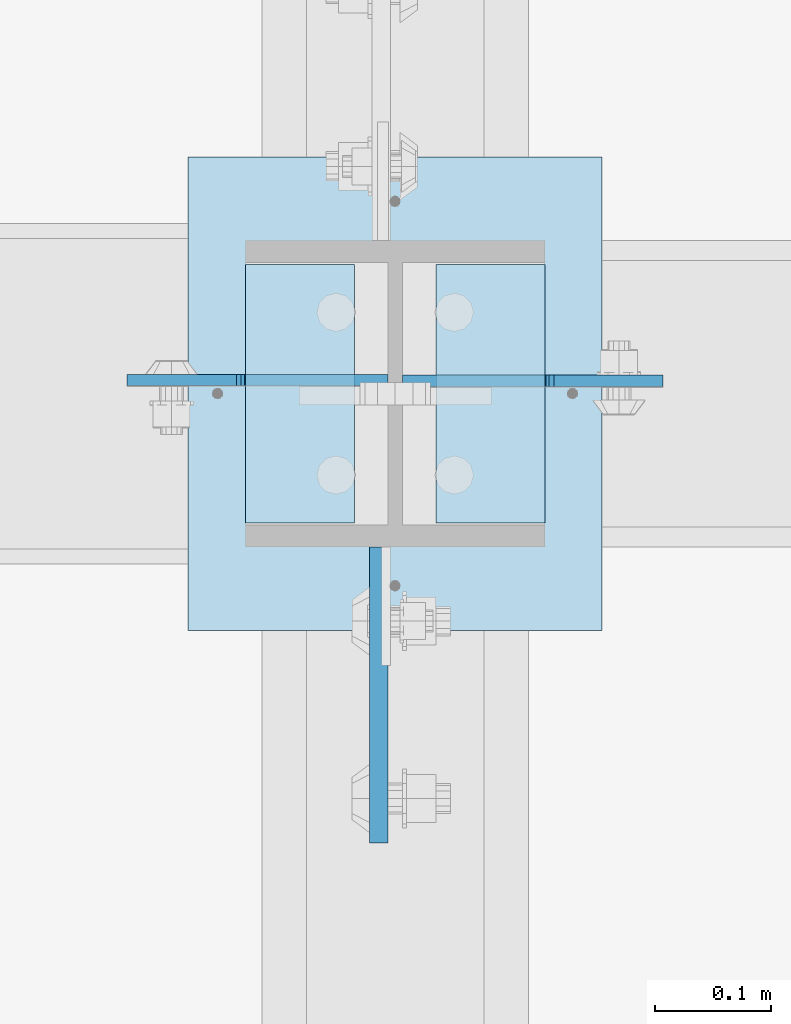
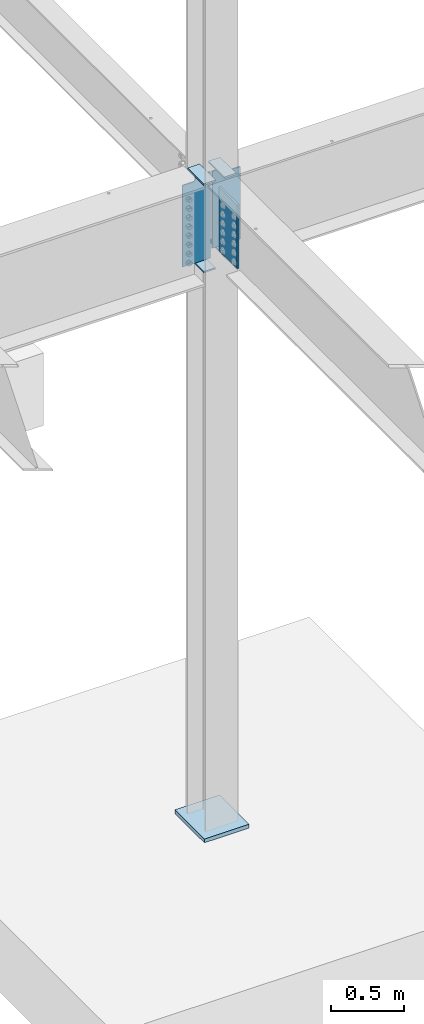
# One storey, part 1564 of 1763: 8 plates, 1 element without a shape of its own.
"""IFC2X3 building model written with IfcOpenShell, lengths in millimetres."""

import ifcopenshell
import ifcopenshell.guid

model = None  # the IFC model being written
_history = None  # IfcOwnerHistory: only IFC2X3 demands one
_inside = {}  # id of a spatial element -> (the spatial element, [elements in it])
_under = {}  # id of a project, library or spatial element -> (it, [spatial elements below it])
_declared = {}  # id of a project -> (the project, [libraries it declares])
_typed = {}  # id of a type object -> (the type object, [elements of that type])
_made_of = {}  # id of a material, layer set ... -> (it, [elements and type objects made of it])


def new_model(schema):
    """Start an empty IFC model of exactly this schema.

    Asked for "IFC4X3", IfcOpenShell would pick the latest addendum, in which some entities
    have other attributes; the version numbers below select the first issue.
    IFC2X3 requires an IfcOwnerHistory on every rooted entity: one is made here for all.
    """
    global model, _history
    if schema == "IFC4X3":
        model = ifcopenshell.file(schema_version=(4, 3, 0, 0))
    else:
        model = ifcopenshell.file(schema=schema)
    _inside.clear()
    _under.clear()
    _declared.clear()
    _typed.clear()
    _made_of.clear()
    _history = None
    if model.schema == "IFC2X3":
        org = make("IfcOrganization", Name="unknown")
        user = make(
            "IfcPersonAndOrganization",
            ThePerson=make("IfcPerson", FamilyName="unknown"),
            TheOrganization=org,
        )
        app = make(
            "IfcApplication",
            ApplicationDeveloper=org,
            Version="unknown",
            ApplicationFullName="unknown",
            ApplicationIdentifier="unknown",
        )
        _history = make(
            "IfcOwnerHistory",
            OwningUser=user,
            OwningApplication=app,
            ChangeAction="ADDED",
            CreationDate=0,
        )
    return model


def make(cls, **values):
    """One entity of the class cls with the attributes given. An attribute that is None is left unset."""
    return model.create_entity(
        cls, **{name: value for name, value in values.items() if value is not None}
    )


def rooted(cls, **values):
    """An entity with a GlobalId (a new one), such as an element, a storey or a relation."""
    return make(cls, GlobalId=ifcopenshell.guid.new(), OwnerHistory=_history, **values)


def si_unit(unit_type, name, prefix=None):
    """IfcSIUnit, for example si_unit("LENGTHUNIT", "METRE", prefix="MILLI")."""
    return make("IfcSIUnit", UnitType=unit_type, Prefix=prefix, Name=name)


def assignment(units):
    """IfcUnitAssignment: the units of a project."""
    return None if units is None else make("IfcUnitAssignment", Units=units)


def point(xyz):
    """IfcCartesianPoint."""
    return None if xyz is None else make("IfcCartesianPoint", Coordinates=xyz)


def direction(xyz):
    """IfcDirection."""
    return None if xyz is None else make("IfcDirection", DirectionRatios=xyz)


def frame(location, z_axis=None, x_axis=None):
    """IfcAxis2Placement3D, a coordinate frame: its origin and axes. An axis left out is left unset."""
    return make(
        "IfcAxis2Placement3D",
        Location=point(location),
        Axis=direction(z_axis),
        RefDirection=direction(x_axis),
    )


def origin_with_axes():
    """The frame at (0, 0, 0) with the z axis (0, 0, 1) and the x axis (1, 0, 0) written out."""
    return frame((0.0, 0.0, 0.0), z_axis=(0.0, 0.0, 1.0), x_axis=(1.0, 0.0, 0.0))


def place(relative_to, where):
    """IfcLocalPlacement: puts the frame where relative to a parent placement (None: the world)."""
    return make(
        "IfcLocalPlacement", PlacementRelTo=relative_to, RelativePlacement=where
    )


def context(
    kind, dimensions, precision=None, world=None, true_north=None, identifier=None
):
    """IfcGeometricRepresentationContext, for example the 3D "Model" context."""
    return make(
        "IfcGeometricRepresentationContext",
        ContextIdentifier=identifier,
        ContextType=kind,
        CoordinateSpaceDimension=dimensions,
        Precision=precision,
        WorldCoordinateSystem=world,
        TrueNorth=true_north,
    )


def subcontext(parent, identifier, kind, view, scale=None):
    """IfcGeometricRepresentationSubContext, for example "Body" below "Model"."""
    return make(
        "IfcGeometricRepresentationSubContext",
        ContextIdentifier=identifier,
        ContextType=kind,
        ParentContext=parent,
        TargetScale=scale,
        TargetView=view,
    )


def project(units=None, contexts=None):
    """IfcProject with its units and contexts."""
    return rooted(
        "IfcProject",
        Name="project",
        RepresentationContexts=contexts,
        UnitsInContext=assignment(units),
    )


def spatial(cls, under=None, at=None, **own):
    """A site, building, storey or space (cls), placed at a placement, below another one or the project."""
    s = rooted(cls, ObjectPlacement=at, **own)
    if under is not None:
        _under.setdefault(under.id(), (under, []))[1].append(s)
    return s


def faces_of(points, faces, orient=None, outer=None):
    """IfcFace entities. A face is a list of loops; a loop is a list of indices into points, from 0.

    orient and outer hold one flag for each loop. By default every Orientation is true, the
    first loop of a face is its IfcFaceOuterBound and the others are IfcFaceBound.
    """
    made = []
    for i, loops in enumerate(faces):
        bounds = []
        for j, loop in enumerate(loops):
            is_outer = j == 0 if outer is None else outer[i][j]
            bounds.append(
                make(
                    "IfcFaceOuterBound" if is_outer else "IfcFaceBound",
                    Bound=make("IfcPolyLoop", Polygon=[points[k] for k in loop]),
                    Orientation=True if orient is None else orient[i][j],
                )
            )
        made.append(make("IfcFace", Bounds=bounds))
    return made


def faceted_brep(points, faces, orient=None, outer=None, voids=None):
    """IfcFacetedBrep: a solid bounded by flat faces; with voids (closed shells), ...WithVoids."""
    shared = [point(p) for p in points]
    hull = make("IfcClosedShell", CfsFaces=faces_of(shared, faces, orient, outer))
    if voids is None:
        return make("IfcFacetedBrep", Outer=hull)
    return make(
        "IfcFacetedBrepWithVoids",
        Outer=hull,
        Voids=[
            make(cls, CfsFaces=faces_of(shared, fs, o, b)) for cls, fs, o, b in voids
        ],
    )


def shape(context_of_items, identifier, shape_type, items):
    """IfcShapeRepresentation: the items that make up one representation, for example the "Body"."""
    return make(
        "IfcShapeRepresentation",
        ContextOfItems=context_of_items,
        RepresentationIdentifier=identifier,
        RepresentationType=shape_type,
        Items=items,
    )


def material(Name=None, Category=None):
    """IfcMaterial."""
    return make("IfcMaterial", Name=Name, Category=Category)


def made_of(thing, what):
    """Note that an element or type object is made of a material, layer set ...; save() writes the relation."""
    if what is not None:
        _made_of.setdefault(what.id(), (what, []))[1].append(thing)
    return thing


def type_object(cls, material=None, **own):
    """A type object (cls), such as IfcWallType, which elements share."""
    return made_of(rooted(cls, **own), material)


def element(
    cls,
    number,
    at=None,
    inside=None,
    cuts=None,
    type_object=None,
    material=None,
    context=None,
    identifier="Body",
    shape_type=None,
    held_by="IfcProductDefinitionShape",
    body=None,
    shapes=None,
    **own,
):
    """One element of the class cls, such as IfcWall. Its Tag is "e" and its number.

    at: its placement. inside: the storey or other place that contains it. cuts: it is an
    opening in that element (IfcRelVoidsElement). A single representation is given by context,
    identifier, shape_type and body (its items); several are given by shapes. held_by: the class
    of the entity that holds the representations. save() writes the other relations.
    """
    e = rooted(cls, Tag="e%d" % number, ObjectPlacement=at, **own)
    if body is not None:
        shapes = [shape(context, identifier, shape_type, body)]
    if shapes is not None:
        e.Representation = make(held_by, Representations=shapes)
    if inside is not None:
        _inside.setdefault(inside.id(), (inside, []))[1].append(e)
    if cuts is not None:
        rooted(
            "IfcRelVoidsElement", RelatingBuildingElement=cuts, RelatedOpeningElement=e
        )
    if type_object is not None:
        _typed.setdefault(type_object.id(), (type_object, []))[1].append(e)
    return made_of(e, material)


def aggregate(whole, parts):
    """IfcRelAggregates: a whole, such as a stair, and the parts it consists of."""
    return rooted("IfcRelAggregates", RelatingObject=whole, RelatedObjects=parts)


def save(model, path):
    """Write the relations noted so far, then the file.

    IfcRelAggregates (storeys below a building ...), IfcRelContainedInSpatialStructure (elements
    in a storey), IfcRelDefinesByType, IfcRelAssociatesMaterial and IfcRelDeclares: one each for
    every whole, place, type object, material and project.
    """
    for whole, parts in _under.values():
        aggregate(whole, parts)
    for where, things in _inside.values():
        rooted(
            "IfcRelContainedInSpatialStructure",
            RelatedElements=things,
            RelatingStructure=where,
        )
    for kind, things in _typed.values():
        rooted("IfcRelDefinesByType", RelatedObjects=things, RelatingType=kind)
    for what, things in _made_of.values():
        rooted("IfcRelAssociatesMaterial", RelatedObjects=things, RelatingMaterial=what)
    for by, libraries in _declared.values():
        rooted("IfcRelDeclares", RelatingContext=by, RelatedDefinitions=libraries)
    model.write(path)


model = new_model("IFC2X3")

# Units and contexts
model_context = context("Model", 3, precision=1e-05, world=origin_with_axes())
body_context = subcontext(model_context, "Body", "Model", "MODEL_VIEW")
ifc_project = project(units=[si_unit("LENGTHUNIT", "METRE", prefix="MILLI"), si_unit("AREAUNIT", "SQUARE_METRE"), si_unit("VOLUMEUNIT", "CUBIC_METRE"), si_unit("MASSUNIT", "GRAM", prefix="KILO"), si_unit("TIMEUNIT", "SECOND"), si_unit("PLANEANGLEUNIT", "RADIAN"), si_unit("SOLIDANGLEUNIT", "STERADIAN"), si_unit("THERMODYNAMICTEMPERATUREUNIT", "DEGREE_CELSIUS"), si_unit("LUMINOUSINTENSITYUNIT", "LUMEN")], contexts=[model_context])

# Site, building, storey
site_placement = place(None, origin_with_axes())
site = spatial("IfcSite", under=ifc_project, at=site_placement, CompositionType="ELEMENT")
building_placement = place(site_placement, origin_with_axes())
building = spatial("IfcBuilding", under=site, at=building_placement, Name="Undefined", CompositionType="ELEMENT")
storey_placement = place(building_placement, origin_with_axes())
storey = spatial("IfcBuildingStorey", under=building, at=storey_placement, Name="Undefined", CompositionType="ELEMENT", Elevation=0.0)

# Assembly, plates
assembly_placement = place(storey_placement, origin_with_axes())
assembly = element("IfcElementAssembly", 1, at=assembly_placement, inside=storey, Name="COLUMN", AssemblyPlace="NOTDEFINED", PredefinedType="RIGID_FRAME")
ifc_material_1 = material(Name="STEEL/A36")
plate_type_1 = type_object("IfcPlateType", PredefinedType="NOTDEFINED")
plate_1_placement = place(assembly_placement, frame((-35078.4247736984, 44916.725, 4451.34997558594), z_axis=(0.0, -1.0, 0.0), x_axis=(1.0, 0.0, 0.0)))
plate_1 = element("IfcPlate", 2, at=plate_1_placement, type_object=plate_type_1, material=ifc_material_1, Name="PLATE", context=body_context, shape_type="Brep", body=[
    faceted_brep([(0.0, -6.34999999999491, 1.45519152283669e-11), (0.0, -6.35000000000036, 222.25), (0.0, 6.35000000000036, 222.25), (0.0, 6.34999999999491, -2.91038304567337e-11), (93.6624984741211, -6.35000000000036, 222.25), (93.6624984741211, 6.35000000000036, 222.25), (93.6624984741211, -6.35000000000036, 0.0), (93.6624984741211, 6.35000000000036, 0.0)], [[[0, 1, 2, 3]], [[1, 4, 5, 2]], [[4, 6, 7, 5]], [[6, 0, 3, 7]], [[5, 7, 3, 2]], [[6, 4, 1, 0]]]),
])
plate_2_placement = place(assembly_placement, frame((-35078.4247736984, 44916.725, 5187.95), z_axis=(0.0, -1.0, 0.0), x_axis=(1.0, 0.0, 0.0)))
plate_2 = element("IfcPlate", 3, at=plate_2_placement, type_object=plate_type_1, material=ifc_material_1, Name="PLATE", context=body_context, shape_type="Brep", body=[
    faceted_brep([(0.0, -6.34999999999491, 1.45519152283669e-11), (0.0, -6.35000000000036, 222.25), (0.0, 6.35000000000036, 222.25), (0.0, 6.34999999999491, -2.91038304567337e-11), (93.6624984741211, -6.35000000000036, 222.25), (93.6624984741211, 6.35000000000036, 222.25), (93.6624984741211, -6.35000000000036, 0.0), (93.6624984741211, 6.35000000000036, 0.0)], [[[0, 1, 2, 3]], [[1, 4, 5, 2]], [[4, 6, 7, 5]], [[6, 0, 3, 7]], [[5, 7, 3, 2]], [[6, 4, 1, 0]]]),
])
plate_3_placement = place(assembly_placement, frame((-34821.2497736983, 44694.475, 4527.54998779297), z_axis=(0.0, 1.0, 0.0), x_axis=(-1.0, 0.0, 0.0)))
plate_3 = element("IfcPlate", 4, at=plate_3_placement, type_object=plate_type_1, material=ifc_material_1, Name="PLATE", context=body_context, shape_type="Brep", body=[
    faceted_brep([(0.0, -6.34999999999491, 1.45519152283669e-11), (0.0, -6.35000000000036, 222.25), (0.0, 6.35000000000036, 222.25), (0.0, 6.34999999999491, -2.91038304567337e-11), (93.6624984741211, -6.35000000000036, 222.25), (93.6624984741211, 6.35000000000036, 222.25), (93.6624984741211, -6.35000000000036, 0.0), (93.6624984741211, 6.35000000000036, 0.0)], [[[0, 1, 2, 3]], [[1, 4, 5, 2]], [[4, 6, 7, 5]], [[6, 0, 3, 7]], [[5, 7, 3, 2]], [[6, 4, 1, 0]]]),
])
plate_4_placement = place(assembly_placement, frame((-34821.2497736983, 44694.475, 5187.95), z_axis=(0.0, 1.0, 0.0), x_axis=(-1.0, 0.0, 0.0)))
plate_4 = element("IfcPlate", 5, at=plate_4_placement, type_object=plate_type_1, material=ifc_material_1, Name="PLATE", context=body_context, shape_type="Brep", body=[
    faceted_brep([(0.0, -6.34999999999491, 1.45519152283669e-11), (0.0, -6.35000000000036, 222.25), (0.0, 6.35000000000036, 222.25), (0.0, 6.34999999999491, -2.91038304567337e-11), (93.6624984741211, -6.35000000000036, 222.25), (93.6624984741211, 6.35000000000036, 222.25), (93.6624984741211, -6.35000000000036, 0.0), (93.6624984741211, 6.35000000000036, 0.0)], [[[0, 1, 2, 3]], [[1, 4, 5, 2]], [[4, 6, 7, 5]], [[6, 0, 3, 7]], [[5, 7, 3, 2]], [[6, 4, 1, 0]]]),
])
ifc_material_2 = material(Name="STEEL/A572-50")
plate_type_2 = type_object("IfcPlateType", PredefinedType="NOTDEFINED")
plate_5_placement = place(assembly_placement, frame((-34964.1247736983, 44673.8375, 5143.5), z_axis=(0.0, -1.0, 0.0), x_axis=(0.0, 0.0, -1.0)))
plate_5 = element("IfcPlate", 6, at=plate_5_placement, type_object=plate_type_2, material=ifc_material_2, Name="PLATE", context=body_context, shape_type="Brep", body=[
    faceted_brep([(-7.27595761418343e-12, -7.9375, 0.0), (0.0, -7.9375, 254.0), (0.0, 7.9375, 254.0), (-7.27595761418343e-12, 7.9375, 0.0), (533.400024414062, -7.9375, 254.0), (533.400024414062, 7.9375, 254.0), (533.400024414062, -7.9375, 0.0), (533.400024414062, 7.9375, 0.0)], [[[0, 1, 2, 3]], [[1, 4, 5, 2]], [[4, 6, 7, 5]], [[6, 0, 3, 7]], [[5, 7, 3, 2]], [[6, 4, 1, 0]]]),
])
plate_type_3 = type_object("IfcPlateType", PredefinedType="NOTDEFINED")
plate_6_placement = place(assembly_placement, frame((-34956.1872736983, 44817.50625, 5181.6), z_axis=(-1.0, 0.0, 0.0), x_axis=(0.0, 0.0, -1.0)))
plate_6 = element("IfcPlate", 7, at=plate_6_placement, type_object=plate_type_3, material=ifc_material_1, Name="PLATE", context=body_context, shape_type="Brep", body=[
    faceted_brep([(25.4000001907334, -4.76250000000073, 122.237503051758), (25.4000001907334, 4.76250000000073, 122.237503051758), (-2.5465851649642e-11, 4.76250000019581, 122.237500000236), (-3.45607986673713e-11, -4.76249999983202, 122.23750000025), (30.2600797087798, -4.76250000000073, 123.204232974349), (30.2600797087798, 4.76250000000073, 123.204232974349), (34.3802561769335, -4.76250000000073, 125.957246874823), (34.3802561769335, 4.76250000000073, 125.957246874823), (37.133270077411, -4.76250000000073, 130.077423342977), (37.133270077411, 4.76250000000073, 130.077423342977), (38.0999999999985, -4.76250000000073, 134.937502861023), (38.0999999999985, 4.76250000000073, 134.937502861023), (38.0999999999985, -4.76250000000073, 223.837493896484), (38.0999999999985, 4.76250000000073, 223.837493896484), (723.900024414062, -4.76250000000073, 0.0), (0.0, -4.76249999999982, 0.0), (0.0, 4.76249999999982, 0.0), (723.900024414062, 4.76250000000073, 0.0), (723.900024414062, -4.76250000000073, 223.837493896484), (723.900024414062, 4.76250000000073, 223.837493896484)], [[[0, 1, 2, 3]], [[4, 5, 1, 0]], [[6, 7, 5, 4]], [[8, 9, 7, 6]], [[10, 11, 9, 8]], [[12, 13, 11, 10]], [[14, 15, 16, 17]], [[18, 14, 17, 19]], [[8, 6, 4, 0, 3, 15, 14, 18, 12, 10]], [[16, 15, 3, 2]], [[19, 17, 16, 2, 1, 5, 7, 9, 11, 13]], [[18, 19, 13, 12]]]),
])
plate_7_placement = place(assembly_placement, frame((-34943.4872736984, 44816.7124999046, 5181.6), z_axis=(1.0, 0.0, 0.0), x_axis=(0.0, 0.0, -1.0)))
plate_7 = element("IfcPlate", 8, at=plate_7_placement, type_object=plate_type_3, material=ifc_material_1, Name="PLATE", context=body_context, shape_type="Brep", body=[
    faceted_brep([(25.4000001907334, -4.76250000000073, 122.237503051758), (25.4000001907334, 4.76250000000073, 122.237503051758), (-2.5465851649642e-11, 4.76250000019581, 122.237500000236), (-3.45607986673713e-11, -4.76249999983202, 122.23750000025), (30.2600797087798, -4.76250000000073, 123.204232974349), (30.2600797087798, 4.76250000000073, 123.204232974349), (34.3802561769335, -4.76250000000073, 125.957246874823), (34.3802561769335, 4.76250000000073, 125.957246874823), (37.133270077411, -4.76250000000073, 130.077423342977), (37.133270077411, 4.76250000000073, 130.077423342977), (38.0999999999985, -4.76250000000073, 134.937502861023), (38.0999999999985, 4.76250000000073, 134.937502861023), (38.0999999999985, -4.76250000000073, 223.837493896484), (38.0999999999985, 4.76250000000073, 223.837493896484), (647.700012207031, -4.76250000000073, 0.0), (0.0, -4.76249999999982, 0.0), (0.0, 4.76249999999982, 0.0), (647.700012207031, 4.76250000000073, 0.0), (647.700012207031, -4.76250000000073, 223.837493896484), (647.700012207031, 4.76250000000073, 223.837493896484)], [[[0, 1, 2, 3]], [[4, 5, 1, 0]], [[6, 7, 5, 4]], [[8, 9, 7, 6]], [[10, 11, 9, 8]], [[12, 13, 11, 10]], [[14, 15, 16, 17]], [[18, 14, 17, 19]], [[8, 6, 4, 0, 3, 15, 14, 18, 12, 10]], [[16, 15, 3, 2]], [[19, 17, 16, 2, 1, 5, 7, 9, 11, 13]], [[18, 19, 13, 12]]]),
])
plate_type_4 = type_object("IfcPlateType", PredefinedType="NOTDEFINED")
plate_8_placement = place(assembly_placement, frame((-35127.6372736984, 45008.8, -250.825), z_axis=(1.0, 0.0, 0.0), x_axis=(0.0, -1.0, 0.0)))
plate_8 = element("IfcPlate", 9, at=plate_8_placement, type_object=plate_type_4, material=ifc_material_1, Name="PLATE", context=body_context, shape_type="Brep", body=[
    faceted_brep([(0.0, -15.875, 0.0), (0.0, -15.875, 355.600006103516), (0.0, 15.875, 355.600006103516), (0.0, 15.875, 0.0), (406.399993896484, -15.875, 355.600006103516), (406.399993896484, 15.875, 355.600006103516), (406.399993896484, -15.875, 0.0), (406.399993896484, 15.875, 0.0)], [[[0, 1, 2, 3]], [[1, 4, 5, 2]], [[4, 6, 7, 5]], [[6, 0, 3, 7]], [[5, 7, 3, 2]], [[6, 4, 1, 0]]]),
])
aggregate(assembly, [plate_1, plate_2, plate_6, plate_3, plate_4, plate_7, plate_5, plate_8])

save(model, "model.ifc")
